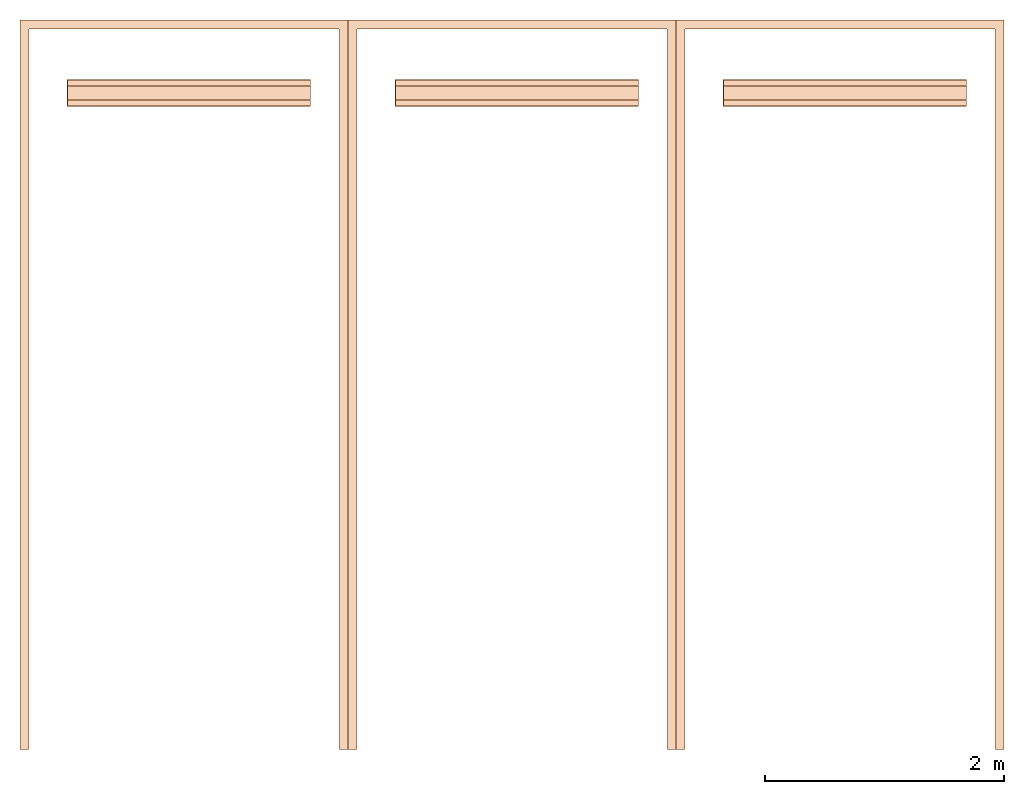
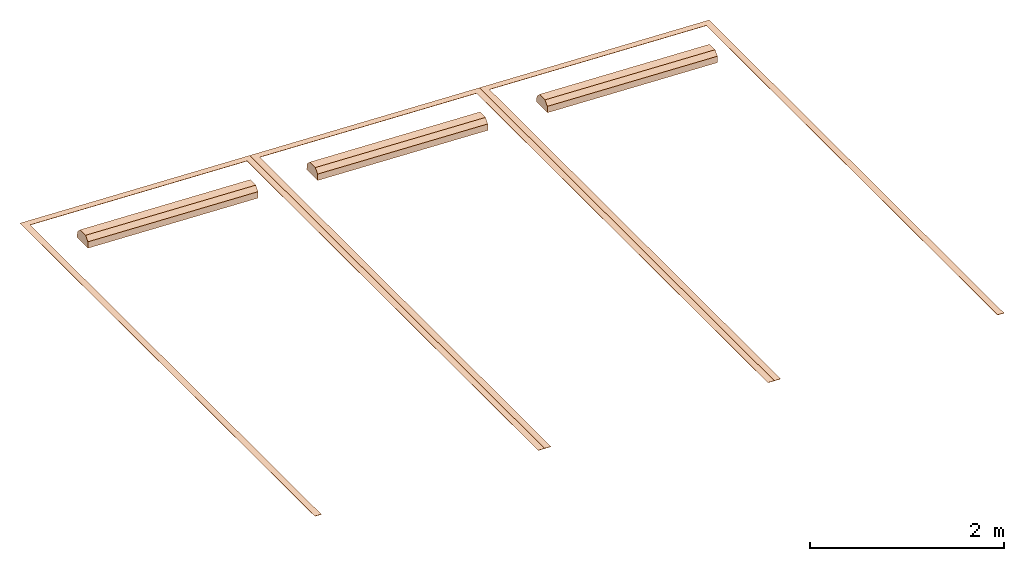
# Not in any storey: 3 geographic elements.
"""IFC4 model written with IfcOpenShell, lengths in feet."""

import ifcopenshell
import ifcopenshell.guid

model = None  # the IFC model being written
_history = None  # IfcOwnerHistory: only IFC2X3 demands one
_inside = {}  # id of a spatial element -> (the spatial element, [elements in it])
_under = {}  # id of a project, library or spatial element -> (it, [spatial elements below it])
_declared = {}  # id of a project -> (the project, [libraries it declares])
_typed = {}  # id of a type object -> (the type object, [elements of that type])
_made_of = {}  # id of a material, layer set ... -> (it, [elements and type objects made of it])


def new_model(schema):
    """Start an empty IFC model of exactly this schema.

    Asked for "IFC4X3", IfcOpenShell would pick the latest addendum, in which some entities
    have other attributes; the version numbers below select the first issue.
    IFC2X3 requires an IfcOwnerHistory on every rooted entity: one is made here for all.
    """
    global model, _history
    if schema == "IFC4X3":
        model = ifcopenshell.file(schema_version=(4, 3, 0, 0))
    else:
        model = ifcopenshell.file(schema=schema)
    _inside.clear()
    _under.clear()
    _declared.clear()
    _typed.clear()
    _made_of.clear()
    _history = None
    if model.schema == "IFC2X3":
        org = make("IfcOrganization", Name="unknown")
        user = make(
            "IfcPersonAndOrganization",
            ThePerson=make("IfcPerson", FamilyName="unknown"),
            TheOrganization=org,
        )
        app = make(
            "IfcApplication",
            ApplicationDeveloper=org,
            Version="unknown",
            ApplicationFullName="unknown",
            ApplicationIdentifier="unknown",
        )
        _history = make(
            "IfcOwnerHistory",
            OwningUser=user,
            OwningApplication=app,
            ChangeAction="ADDED",
            CreationDate=0,
        )
    return model


def make(cls, **values):
    """One entity of the class cls with the attributes given. An attribute that is None is left unset."""
    return model.create_entity(
        cls, **{name: value for name, value in values.items() if value is not None}
    )


def entity(cls, *values):
    """Any entity or typed value of the class cls, its attributes in the order of the schema. None: left unset."""
    e = model.create_entity(cls)
    for i, value in enumerate(values):
        if value is not None:
            e[i] = value
    return e


def rooted(cls, **values):
    """An entity with a GlobalId (a new one), such as an element, a storey or a relation."""
    return make(cls, GlobalId=ifcopenshell.guid.new(), OwnerHistory=_history, **values)


def si_unit(unit_type, name, prefix=None):
    """IfcSIUnit, for example si_unit("LENGTHUNIT", "METRE", prefix="MILLI")."""
    return make("IfcSIUnit", UnitType=unit_type, Prefix=prefix, Name=name)


def converted_unit(unit_type, name, factor, base, dimensions=None, offset=None):
    """IfcConversionBasedUnit, such as the inch: factor (a typed value) times the base unit."""
    return make(
        "IfcConversionBasedUnit"
        if offset is None
        else "IfcConversionBasedUnitWithOffset",
        ConversionOffset=offset,
        Dimensions=None
        if dimensions is None
        else entity("IfcDimensionalExponents", *dimensions),
        UnitType=unit_type,
        Name=name,
        ConversionFactor=make(
            "IfcMeasureWithUnit", ValueComponent=factor, UnitComponent=base
        ),
    )


def assignment(units):
    """IfcUnitAssignment: the units of a project."""
    return None if units is None else make("IfcUnitAssignment", Units=units)


def point(xyz):
    """IfcCartesianPoint."""
    return None if xyz is None else make("IfcCartesianPoint", Coordinates=xyz)


def direction(xyz):
    """IfcDirection."""
    return None if xyz is None else make("IfcDirection", DirectionRatios=xyz)


def frame(location, z_axis=None, x_axis=None):
    """IfcAxis2Placement3D, a coordinate frame: its origin and axes. An axis left out is left unset."""
    return make(
        "IfcAxis2Placement3D",
        Location=point(location),
        Axis=direction(z_axis),
        RefDirection=direction(x_axis),
    )


def frame_2d(location, x_axis=None):
    """IfcAxis2Placement2D, a coordinate frame in the plane: its origin and x axis."""
    return make(
        "IfcAxis2Placement2D", Location=point(location), RefDirection=direction(x_axis)
    )


def origin_with_axes():
    """The frame at (0, 0, 0) with the z axis (0, 0, 1) and the x axis (1, 0, 0) written out."""
    return frame((0.0, 0.0, 0.0), z_axis=(0.0, 0.0, 1.0), x_axis=(1.0, 0.0, 0.0))


def origin_2d_with_axis():
    """The frame at (0, 0) in the plane with the x axis (1, 0) written out."""
    return frame_2d((0.0, 0.0), x_axis=(1.0, 0.0))


def place(relative_to, where):
    """IfcLocalPlacement: puts the frame where relative to a parent placement (None: the world)."""
    return make(
        "IfcLocalPlacement", PlacementRelTo=relative_to, RelativePlacement=where
    )


def context(
    kind, dimensions, precision=None, world=None, true_north=None, identifier=None
):
    """IfcGeometricRepresentationContext, for example the 3D "Model" context."""
    return make(
        "IfcGeometricRepresentationContext",
        ContextIdentifier=identifier,
        ContextType=kind,
        CoordinateSpaceDimension=dimensions,
        Precision=precision,
        WorldCoordinateSystem=world,
        TrueNorth=true_north,
    )


def subcontext(parent, identifier, kind, view, scale=None):
    """IfcGeometricRepresentationSubContext, for example "Body" below "Model"."""
    return make(
        "IfcGeometricRepresentationSubContext",
        ContextIdentifier=identifier,
        ContextType=kind,
        ParentContext=parent,
        TargetScale=scale,
        TargetView=view,
    )


def project(units=None, contexts=None):
    """IfcProject with its units and contexts."""
    return rooted(
        "IfcProject",
        Name="project",
        RepresentationContexts=contexts,
        UnitsInContext=assignment(units),
    )


def point_list(points):
    """IfcCartesianPointList2D or 3D."""
    cls = (
        "IfcCartesianPointList2D" if len(points[0]) == 2 else "IfcCartesianPointList3D"
    )
    return make(cls, CoordList=points)


def polygons(points, faces, closed=None, point_numbers=None):
    """IfcPolygonalFaceSet: a face is its outer loop, then its inner loops; points numbered from 1."""
    made = []
    for loops in faces:
        if len(loops) == 1:
            made.append(make("IfcIndexedPolygonalFace", CoordIndex=loops[0]))
        else:
            made.append(
                make(
                    "IfcIndexedPolygonalFaceWithVoids",
                    CoordIndex=loops[0],
                    InnerCoordIndices=loops[1:],
                )
            )
    return make(
        "IfcPolygonalFaceSet",
        Coordinates=point_list(points),
        Closed=closed,
        Faces=made,
        PnIndex=point_numbers,
    )


def shape(context_of_items, identifier, shape_type, items):
    """IfcShapeRepresentation: the items that make up one representation, for example the "Body"."""
    return make(
        "IfcShapeRepresentation",
        ContextOfItems=context_of_items,
        RepresentationIdentifier=identifier,
        RepresentationType=shape_type,
        Items=items,
    )


def source(mapping_origin, context_of_items, identifier, shape_type, items):
    """IfcRepresentationMap: a shape defined once, which mapped items show again and again."""
    return make(
        "IfcRepresentationMap",
        MappingOrigin=mapping_origin,
        MappedRepresentation=shape(context_of_items, identifier, shape_type, items),
    )


def transform(
    local_origin,
    x_axis=None,
    y_axis=None,
    z_axis=None,
    scale=None,
    scale2=None,
    scale3=None,
    uniform=True,
):
    """IfcCartesianTransformationOperator3D, or its non-uniform kind. x_axis, y_axis, z_axis: its Axis1, 2, 3."""
    if uniform:
        return make(
            "IfcCartesianTransformationOperator3D",
            Axis1=direction(x_axis),
            Axis2=direction(y_axis),
            LocalOrigin=point(local_origin),
            Scale=scale,
            Axis3=direction(z_axis),
        )
    return make(
        "IfcCartesianTransformationOperator3DnonUniform",
        Axis1=direction(x_axis),
        Axis2=direction(y_axis),
        LocalOrigin=point(local_origin),
        Scale=scale,
        Axis3=direction(z_axis),
        Scale2=scale2,
        Scale3=scale3,
    )


def mapped(mapping_source, mapping_target):
    """IfcMappedItem: shows the shape of a source again, moved by a transform."""
    return make(
        "IfcMappedItem", MappingSource=mapping_source, MappingTarget=mapping_target
    )


def material(Name=None, Category=None):
    """IfcMaterial."""
    return make("IfcMaterial", Name=Name, Category=Category)


def made_of(thing, what):
    """Note that an element or type object is made of a material, layer set ...; save() writes the relation."""
    if what is not None:
        _made_of.setdefault(what.id(), (what, []))[1].append(thing)
    return thing


def type_object(cls, material=None, **own):
    """A type object (cls), such as IfcWallType, which elements share."""
    return made_of(rooted(cls, **own), material)


def type_shapes(of_type, sources):
    """Give a type object the sources (RepresentationMaps) that its elements show as mapped items."""
    of_type.RepresentationMaps = sources


def element(
    cls,
    number,
    at=None,
    inside=None,
    cuts=None,
    type_object=None,
    material=None,
    context=None,
    identifier="Body",
    shape_type=None,
    held_by="IfcProductDefinitionShape",
    body=None,
    shapes=None,
    **own,
):
    """One element of the class cls, such as IfcWall. Its Tag is "e" and its number.

    at: its placement. inside: the storey or other place that contains it. cuts: it is an
    opening in that element (IfcRelVoidsElement). A single representation is given by context,
    identifier, shape_type and body (its items); several are given by shapes. held_by: the class
    of the entity that holds the representations. save() writes the other relations.
    """
    e = rooted(cls, Tag="e%d" % number, ObjectPlacement=at, **own)
    if body is not None:
        shapes = [shape(context, identifier, shape_type, body)]
    if shapes is not None:
        e.Representation = make(held_by, Representations=shapes)
    if inside is not None:
        _inside.setdefault(inside.id(), (inside, []))[1].append(e)
    if cuts is not None:
        rooted(
            "IfcRelVoidsElement", RelatingBuildingElement=cuts, RelatedOpeningElement=e
        )
    if type_object is not None:
        _typed.setdefault(type_object.id(), (type_object, []))[1].append(e)
    return made_of(e, material)


def aggregate(whole, parts):
    """IfcRelAggregates: a whole, such as a stair, and the parts it consists of."""
    return rooted("IfcRelAggregates", RelatingObject=whole, RelatedObjects=parts)


def save(model, path):
    """Write the relations noted so far, then the file.

    IfcRelAggregates (storeys below a building ...), IfcRelContainedInSpatialStructure (elements
    in a storey), IfcRelDefinesByType, IfcRelAssociatesMaterial and IfcRelDeclares: one each for
    every whole, place, type object, material and project.
    """
    for whole, parts in _under.values():
        aggregate(whole, parts)
    for where, things in _inside.values():
        rooted(
            "IfcRelContainedInSpatialStructure",
            RelatedElements=things,
            RelatingStructure=where,
        )
    for kind, things in _typed.values():
        rooted("IfcRelDefinesByType", RelatedObjects=things, RelatingType=kind)
    for what, things in _made_of.values():
        rooted("IfcRelAssociatesMaterial", RelatedObjects=things, RelatingMaterial=what)
    for by, libraries in _declared.values():
        rooted("IfcRelDeclares", RelatingContext=by, RelatedDefinitions=libraries)
    model.write(path)


model = new_model("IFC4")

# Units and contexts
model_context = context("Model", 3, precision=1e-05, world=origin_with_axes())
plan_context = context("Plan", 2, precision=1e-05, world=origin_2d_with_axis())
context_of_model = context(None, 3, precision=1e-05, world=origin_with_axes())
body_context = subcontext(model_context, "Body", "Model", "MODEL_VIEW")
ifc_project = project(units=[converted_unit("PLANEANGLEUNIT", "degree", entity("IfcReal", 0.0174532925199433), si_unit("PLANEANGLEUNIT", "RADIAN"), dimensions=[0, 0, 0, 0, 0, 0, 0]), converted_unit("AREAUNIT", "square foot", entity("IfcReal", 0.09290304), si_unit("AREAUNIT", "SQUARE_METRE"), dimensions=[2, 0, 0, 0, 0, 0, 0]), converted_unit("LENGTHUNIT", "foot", entity("IfcReal", 0.3048), si_unit("LENGTHUNIT", "METRE"), dimensions=[1, 0, 0, 0, 0, 0, 0]), converted_unit("VOLUMEUNIT", "cubic foot", entity("IfcReal", 0.0283168467116885), si_unit("VOLUMEUNIT", "CUBIC_METRE"), dimensions=[3, 0, 0, 0, 0, 0, 0])], contexts=[model_context, plan_context, context_of_model, context_of_model])

# Geographic elements
ifc_material = material(Name="PARKING STALL")
geographic_element_type = type_object("IfcGeographicElementType", Name="PARKING STALL", PredefinedType="NOTDEFINED", material=ifc_material)
shared_shape = source(origin_with_axes(), body_context, "Body", "Tessellation", [
    polygons([(-9.0, -7.76511660660617e-06, 0.0), (0.0, -2.91397121547372e-14, 0.0), (-0.250000029802322, 0.25, 0.0), (-8.75, 0.250000089406967, 0.0), (9.77524109657679e-07, 20.0, 0.0), (-0.249999046325684, 20.0, 0.0), (-8.99999904632568, 19.9999923706055, 0.0), (-8.74999904632568, 20.0, 0.0), (-9.0, -7.76511660660617e-06, 0.0104167331010103), (-0.250000029802322, 0.25, 0.0104167331010103), (-8.75, 0.250000089406967, 0.0104167331010103), (0.0, -2.91397121547372e-14, 0.0104167331010103), (-8.99999904632568, 19.9999923706055, 0.0104167331010103), (-8.74999904632568, 20.0, 0.0104167331010103), (9.77524109657679e-07, 20.0, 0.0104167331010103), (-0.249999046325684, 20.0, 0.0104167331010103), (-7.95833301544189, 2.35416650772095, 0.260416656732559), (-1.2916671037674, 2.1875, 0.427083313465118), (-1.2916671037674, 2.35416650772095, 0.260416656732559), (-7.95833301544189, 2.1875, 0.427083313465118), (-7.95833301544189, 2.375, 0.0104166669771075), (-7.95833301544189, 1.62500011920929, 0.0104166669771075), (-7.95833301544189, 1.8125, 0.427083313465118), (-7.95833301544189, 1.64583325386047, 0.260416656732559), (-1.2916671037674, 2.375, 0.0104166669771075), (-1.2916671037674, 1.8125, 0.427083313465118), (-1.2916671037674, 1.625, 0.0104166669771075), (-1.2916671037674, 1.64583325386047, 0.260416656732559)], [[[1, 3, 2]], [[4, 3, 1]], [[5, 2, 3]], [[6, 5, 3]], [[7, 8, 4]], [[7, 4, 1]], [[11, 9, 10]], [[12, 10, 9]], [[13, 9, 11]], [[14, 13, 11]], [[15, 16, 10]], [[15, 10, 12]], [[10, 16, 6]], [[3, 10, 6]], [[12, 2, 5]], [[12, 5, 15]], [[11, 4, 8]], [[11, 8, 14]], [[15, 5, 6]], [[15, 6, 16]], [[8, 7, 13]], [[8, 13, 14]], [[1, 2, 12]], [[1, 12, 9]], [[1, 13, 7]], [[1, 9, 13]], [[10, 3, 4]], [[10, 4, 11]], [[18, 19, 17]], [[18, 17, 20]], [[21, 20, 17]], [[24, 23, 22]], [[22, 23, 20]], [[22, 20, 21]], [[18, 25, 19]], [[26, 27, 25]], [[26, 25, 18]], [[28, 27, 26]], [[27, 28, 24]], [[27, 24, 22]], [[19, 25, 21]], [[19, 21, 17]], [[22, 21, 25]], [[22, 25, 27]], [[18, 20, 23]], [[23, 26, 18]], [[23, 24, 28]], [[23, 28, 26]]], closed=True),
])
type_shapes(geographic_element_type, [shared_shape])
for number, where, z_axis, x_axis in (
    (1, (79.5193481945929, -171.651489778454, 8.24851079249945), (0.0383878047476672, 9.14313857727914e-09, 0.999262916577341), (-0.999262916577183, -5.63844018702996e-07, 0.0383878047476611)),
    (2, (88.5127097602904, -171.651477263043, 7.90301974364153), (0.0383878047476672, 1.15835677390945e-08, 0.999262916577341), (-0.999262916577145, -6.27370176471347e-07, 0.0383878047476597)),
    (3, (97.506071325988, -171.651464747632, 7.55752947699679), (0.0383878047476672, 1.15835677390945e-08, 0.999262916577341), (-0.999262916577145, -6.27370176471347e-07, 0.0383878047476597)),
):
    element("IfcGeographicElement", number, at=place(None, frame(where, z_axis=z_axis, x_axis=x_axis)), type_object=geographic_element_type, context=body_context, shape_type="MappedRepresentation", body=[
        mapped(shared_shape, transform((0.0, 0.0, 0.0), x_axis=(1.0, 0.0, 0.0), y_axis=(0.0, 1.0, 0.0), z_axis=(0.0, 0.0, 1.0), scale=1.0)),
    ])

save(model, "model.ifc")
